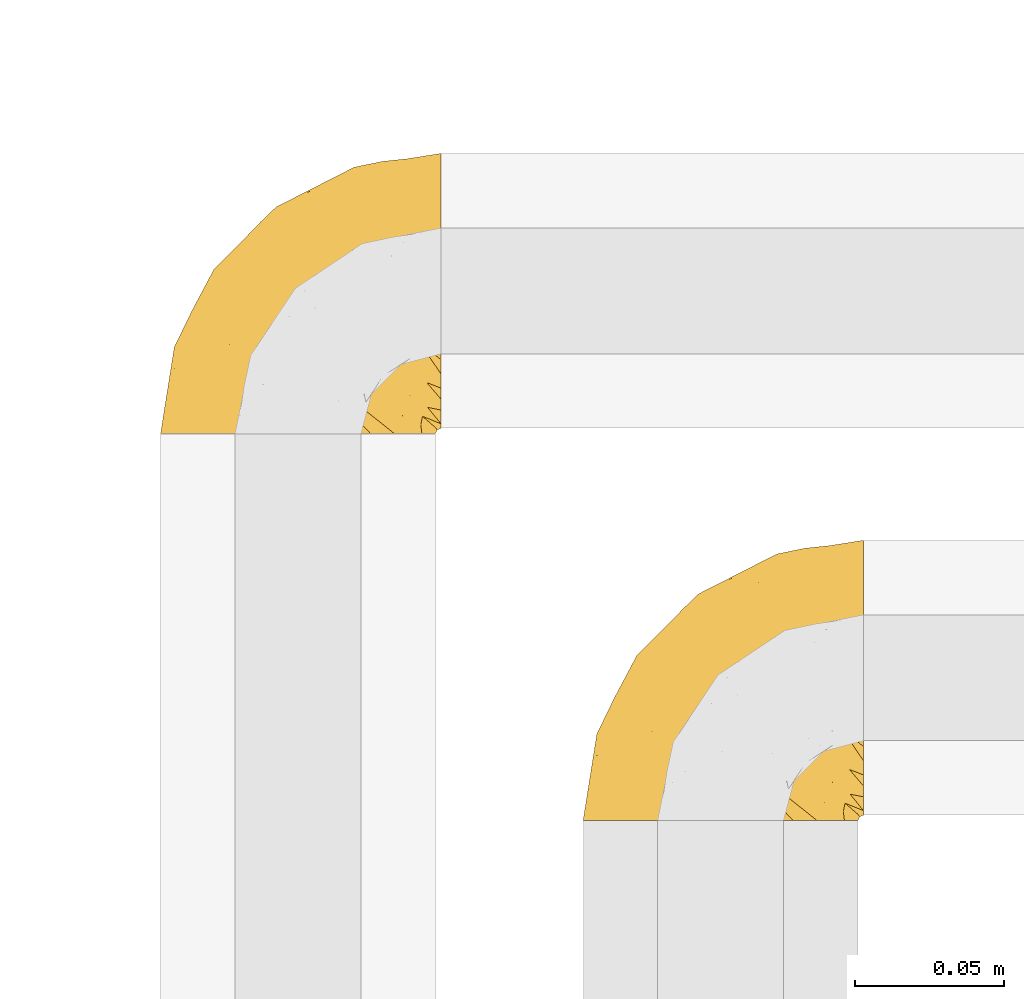
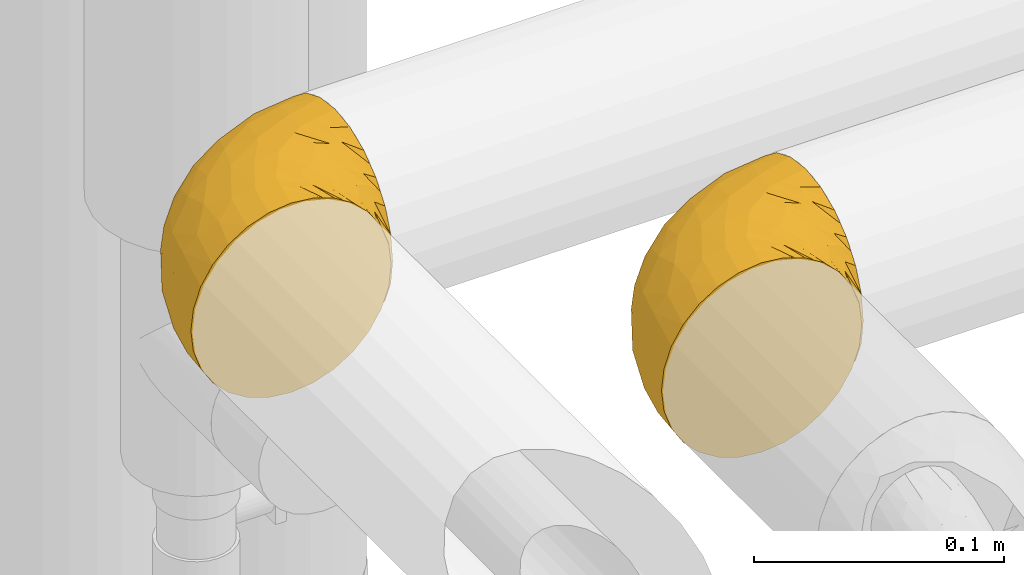
# One storey, part 248 of 827: 2 coverings.
"""IFC2X3 building model written with IfcOpenShell, lengths in millimetres."""

from ifc_helpers import new_model, entity, si_unit, converted_unit, derived_unit, direction, frame, origin, place, context, subcontext, project, spatial, faceted_brep, element, save


model = new_model("IFC2X3")

# Units and contexts
model_context = context("Model", 3, precision=0.01, world=origin(), true_north=direction((6.12303176911189e-17, 1.0)))
body_context = subcontext(model_context, "Body", "Model", "MODEL_VIEW")
ifc_project = project(units=[si_unit("LENGTHUNIT", "METRE", prefix="MILLI"), si_unit("AREAUNIT", "SQUARE_METRE"), si_unit("VOLUMEUNIT", "CUBIC_METRE"), converted_unit("PLANEANGLEUNIT", "DEGREE", entity("IfcRatioMeasure", 0.0174532925199433), si_unit("PLANEANGLEUNIT", "RADIAN"), dimensions=[0, 0, 0, 0, 0, 0, 0]), si_unit("MASSUNIT", "GRAM", prefix="KILO"), derived_unit("MASSDENSITYUNIT", [(si_unit("MASSUNIT", "GRAM", prefix="KILO"), 1), (si_unit("LENGTHUNIT", "METRE"), -3)]), derived_unit("MOMENTOFINERTIAUNIT", [(si_unit("LENGTHUNIT", "METRE"), 4)]), si_unit("TIMEUNIT", "SECOND"), si_unit("FREQUENCYUNIT", "HERTZ"), si_unit("THERMODYNAMICTEMPERATUREUNIT", "DEGREE_CELSIUS"), derived_unit("THERMALTRANSMITTANCEUNIT", [(si_unit("MASSUNIT", "GRAM", prefix="KILO"), 1), (si_unit("THERMODYNAMICTEMPERATUREUNIT", "KELVIN"), -1), (si_unit("TIMEUNIT", "SECOND"), -3)]), derived_unit("VOLUMETRICFLOWRATEUNIT", [(si_unit("LENGTHUNIT", "METRE"), 3), (si_unit("TIMEUNIT", "SECOND"), -1)]), derived_unit("MASSFLOWRATEUNIT", [(si_unit("MASSUNIT", "GRAM", prefix="KILO"), 1), (si_unit("TIMEUNIT", "SECOND"), -1)]), derived_unit("ROTATIONALFREQUENCYUNIT", [(si_unit("TIMEUNIT", "SECOND"), -1)]), si_unit("ELECTRICCURRENTUNIT", "AMPERE"), si_unit("ELECTRICVOLTAGEUNIT", "VOLT"), si_unit("POWERUNIT", "WATT"), si_unit("FORCEUNIT", "NEWTON", prefix="KILO"), si_unit("ILLUMINANCEUNIT", "LUX"), si_unit("LUMINOUSFLUXUNIT", "LUMEN"), si_unit("LUMINOUSINTENSITYUNIT", "CANDELA"), derived_unit("USERDEFINED", [(si_unit("MASSUNIT", "GRAM", prefix="KILO"), -1), (si_unit("LENGTHUNIT", "METRE"), -2), (si_unit("TIMEUNIT", "SECOND"), 3), (si_unit("LUMINOUSFLUXUNIT", "LUMEN"), 1)]), derived_unit("LINEARVELOCITYUNIT", [(si_unit("LENGTHUNIT", "METRE"), 1), (si_unit("TIMEUNIT", "SECOND"), -1)]), si_unit("PRESSUREUNIT", "PASCAL"), derived_unit("USERDEFINED", [(si_unit("LENGTHUNIT", "METRE"), -2), (si_unit("MASSUNIT", "GRAM", prefix="KILO"), 1), (si_unit("TIMEUNIT", "SECOND"), -2)]), derived_unit("LINEARFORCEUNIT", [(si_unit("MASSUNIT", "GRAM", prefix="KILO"), 1), (si_unit("LENGTHUNIT", "METRE"), 1), (si_unit("TIMEUNIT", "SECOND"), -2), (si_unit("LENGTHUNIT", "METRE"), -1)]), derived_unit("PLANARFORCEUNIT", [(si_unit("MASSUNIT", "GRAM", prefix="KILO"), 1), (si_unit("LENGTHUNIT", "METRE"), 1), (si_unit("TIMEUNIT", "SECOND"), -2), (si_unit("LENGTHUNIT", "METRE"), -2)])], contexts=[model_context])

# Site, building, storey
site_placement = place(None, origin())
site = spatial("IfcSite", under=ifc_project, at=site_placement, CompositionType="ELEMENT")
building_placement = place(site_placement, origin())
building = spatial("IfcBuilding", under=site, at=building_placement, CompositionType="ELEMENT")
storey_placement = place(building_placement, frame((0.0, 0.0, 28200.0)))
storey = spatial("IfcBuildingStorey", under=building, at=storey_placement, Name="08", CompositionType="ELEMENT", Elevation=28200.0)

# Coverings
covering_1_placement = place(storey_placement, frame((30515.73, 16011.61, 3152.2)))
element("IfcCovering", 1, at=covering_1_placement, inside=storey, Name=":ADSK_", ObjectType=":ADSK_", PredefinedType="INSULATION", context=body_context, shape_type="Brep", body=[
    faceted_brep([(37.51, 1.6, 92.84), (27.74, 1.6, 89.42), (18.98, 1.6, 83.91), (11.67, 1.6, 76.59), (6.17, 1.6, 67.83), (2.75, 1.6, 58.07), (1.6, 1.6, 47.8), (2.75, 1.6, 37.51), (6.17, 1.6, 27.74), (11.68, 1.6, 18.98), (19.0, 1.6, 11.67), (27.76, 1.6, 6.17), (37.52, 1.6, 2.75), (47.8, 1.6, 1.6), (51.94, 1.6, 2.06), (55.01, 1.6, 2.41), (58.08, 1.6, 2.75), (62.96, 1.6, 4.46), (67.85, 1.6, 6.17), (72.23, 1.6, 8.93), (76.61, 1.6, 11.68), (80.26, 1.6, 15.34), (83.92, 1.6, 19.0), (89.42, 1.6, 27.76), (91.13, 1.6, 32.64), (92.84, 1.6, 37.52), (94.0, 1.6, 47.8), (92.84, 1.6, 58.08), (91.13, 1.6, 62.96), (89.42, 1.6, 67.85), (83.91, 1.6, 76.61), (80.25, 1.6, 80.26), (76.59, 1.6, 83.92), (72.21, 1.6, 86.67), (67.83, 1.6, 89.42), (62.95, 1.6, 91.13), (58.07, 1.6, 92.84), (55.0, 1.6, 93.18), (51.94, 1.6, 93.53), (47.8, 1.6, 94.0), (95.8, 3.4, 47.8), (95.8, 4.97, 35.84), (95.8, 9.58, 24.7), (95.8, 13.26, 19.91), (95.8, 16.93, 15.13), (95.8, 21.71, 11.46), (95.8, 26.5, 7.78), (95.8, 32.07, 5.48), (95.8, 37.64, 3.17), (95.8, 41.25, 2.69), (95.8, 43.34, 2.42), (95.8, 45.42, 2.14), (95.8, 49.6, 1.6), (95.8, 61.55, 3.17), (95.8, 72.7, 7.78), (95.8, 82.26, 15.13), (95.8, 89.61, 24.7), (95.8, 94.22, 35.84), (95.8, 95.8, 47.8), (95.8, 94.22, 59.75), (95.8, 89.61, 70.9), (95.8, 82.26, 80.46), (95.8, 72.7, 87.81), (95.8, 61.55, 92.42), (95.8, 49.6, 94.0), (95.8, 45.42, 93.45), (95.8, 41.25, 92.9), (95.8, 37.64, 92.42), (95.8, 32.07, 90.11), (95.8, 26.5, 87.81), (95.8, 21.71, 84.13), (95.8, 16.93, 80.46), (95.8, 13.26, 75.68), (95.8, 9.58, 70.9), (95.8, 4.97, 59.75), (60.58, 81.55, 71.98), (74.11, 90.4, 63.6), (51.59, 83.0, 59.72), (66.69, 91.18, 47.8), (76.19, 93.13, 55.16), (84.43, 94.0, 47.8), (31.2, 66.19, 63.76), (42.88, 70.92, 72.22), (79.41, 85.95, 74.18), (60.7, 49.74, 92.52), (61.85, 35.54, 94.0), (65.75, 38.14, 94.0), (69.64, 40.74, 94.0), (73.53, 43.34, 94.0), (77.43, 45.94, 94.0), (74.59, 77.59, 82.14), (54.72, 71.17, 80.34), (64.18, 65.81, 87.52), (37.94, 59.03, 79.59), (25.89, 45.85, 78.25), (34.73, 45.79, 85.01), (42.89, 41.42, 90.25), (49.83, 34.51, 93.2), (48.58, 56.04, 87.23), (22.41, 15.15, 85.55), (78.69, 56.51, 93.0), (81.64, 68.39, 89.31), (6.22, 23.33, 61.31), (12.11, 42.86, 56.86), (14.81, 39.42, 68.34), (21.61, 53.58, 65.71), (22.41, 59.17, 56.99), (30.12, 59.06, 72.15), (10.01, 22.63, 70.34), (15.36, 20.55, 78.36), (3.39, 12.96, 47.8), (19.59, 56.96, 47.8), (30.01, 67.38, 47.8), (41.19, 18.72, 93.06), (48.54, 5.33, 94.0), (49.28, 9.07, 94.0), (49.82, 11.79, 94.0), (50.37, 14.51, 94.0), (50.91, 17.24, 94.0), (51.45, 19.96, 94.0), (31.61, 21.03, 89.88), (80.15, 46.48, 94.0), (82.88, 47.03, 94.0), (85.6, 47.57, 94.0), (88.32, 48.11, 94.0), (90.19, 48.48, 94.0), (92.06, 48.85, 94.0), (6.21, 30.7, 47.8), (54.05, 23.86, 94.0), (56.65, 27.75, 94.0), (59.25, 31.64, 94.0), (24.66, 31.26, 83.7), (40.43, 77.8, 47.8), (35.17, 72.75, 55.9), (12.9, 43.83, 47.8), (53.56, 84.49, 47.8), (85.34, 14.58, 81.75), (78.44, 16.17, 86.43), (84.37, 10.82, 79.8), (89.05, 4.64, 69.84), (82.76, 7.71, 79.5), (86.31, 25.13, 88.08), (83.73, 32.66, 91.6), (77.31, 34.94, 92.93), (87.78, 36.76, 92.43), (87.91, 40.48, 93.24), (81.29, 39.25, 93.36), (93.97, 3.69, 57.25), (70.76, 13.99, 89.41), (63.67, 21.85, 92.89), (62.62, 17.93, 92.66), (90.64, 15.11, 79.58), (84.08, 21.14, 86.51), (76.28, 12.7, 86.29), (77.45, 7.21, 83.91), (91.35, 10.45, 73.94), (88.72, 32.27, 90.94), (71.28, 25.68, 91.94), (68.09, 22.18, 91.98), (91.07, 18.79, 82.79), (57.47, 10.12, 93.16), (70.34, 9.47, 88.76), (62.99, 11.29, 91.89), (94.52, 2.87, 47.8), (76.47, 31.16, 92.22), (69.96, 6.31, 88.56), (89.86, 25.62, 87.72), (78.94, 21.18, 88.33), (73.51, 28.81, 92.18), (89.62, 7.45, 71.78), (84.09, 21.14, 9.09), (86.3, 25.13, 7.51), (91.06, 18.79, 12.8), (88.32, 48.11, 1.6), (92.06, 48.85, 1.6), (82.88, 47.03, 1.6), (85.6, 47.57, 1.6), (93.97, 3.69, 38.35), (89.63, 7.44, 23.84), (50.37, 14.51, 1.6), (49.82, 11.79, 1.6), (48.54, 5.33, 1.6), (49.28, 9.07, 1.6), (82.77, 7.71, 16.1), (70.36, 9.47, 6.84), (77.31, 34.94, 2.66), (76.47, 31.16, 3.37), (69.64, 40.74, 1.6), (65.75, 38.14, 1.6), (87.78, 36.76, 3.16), (87.91, 40.48, 2.35), (89.06, 4.63, 25.77), (90.65, 15.11, 16.02), (85.35, 14.58, 13.85), (73.53, 43.34, 1.6), (77.43, 45.94, 1.6), (81.29, 39.25, 2.23), (77.46, 7.21, 11.69), (76.29, 12.69, 9.31), (57.47, 10.14, 2.43), (63.71, 21.81, 2.71), (68.11, 22.19, 3.61), (70.77, 14.0, 6.18), (71.31, 25.69, 3.66), (78.46, 16.17, 9.17), (69.52, 6.66, 6.77), (62.64, 17.92, 2.93), (91.35, 10.45, 21.66), (59.25, 31.64, 1.6), (84.6, 10.64, 16.09), (62.98, 11.31, 3.7), (51.45, 19.96, 1.6), (54.05, 23.86, 1.6), (56.65, 27.75, 1.6), (83.73, 32.66, 3.99), (80.15, 46.48, 1.6), (88.72, 32.27, 4.65), (61.85, 35.54, 1.6), (73.56, 28.77, 3.43), (78.96, 21.17, 7.27), (91.36, 23.36, 9.46), (50.91, 17.24, 1.6), (62.87, 47.58, 2.4), (76.19, 93.13, 40.43), (73.57, 77.44, 13.57), (56.07, 66.78, 11.3), (49.77, 71.68, 18.65), (44.73, 74.96, 27.26), (60.58, 81.55, 23.61), (47.64, 36.7, 3.07), (78.32, 56.9, 2.69), (51.59, 83.0, 35.87), (74.11, 90.4, 31.99), (76.04, 67.83, 6.71), (79.41, 85.95, 21.41), (14.82, 39.41, 27.24), (6.22, 23.33, 34.26), (12.12, 42.87, 38.73), (23.51, 53.92, 26.97), (31.2, 66.19, 31.83), (34.96, 64.12, 23.4), (33.86, 33.13, 6.91), (38.94, 23.1, 3.4), (30.23, 16.98, 5.84), (35.17, 72.75, 39.69), (15.85, 23.77, 17.6), (22.59, 18.41, 10.38), (21.56, 43.7, 20.6), (55.94, 54.53, 5.36), (20.67, 55.72, 35.73), (9.19, 17.73, 24.84), (25.79, 38.98, 13.87), (41.16, 50.28, 9.06), (37.95, 59.02, 15.99)], [[[0, 1, 2, 3, 4, 5, 6, 7, 8, 9, 10, 11, 12, 13, 14, 15, 16, 17, 18, 19, 20, 21, 22, 23, 24, 25, 26, 27, 28, 29, 30, 31, 32, 33, 34, 35, 36, 37, 38, 39]], [[40, 41, 42, 43, 44, 45, 46, 47, 48, 49, 50, 51, 52, 53, 54, 55, 56, 57, 58, 59, 60, 61, 62, 63, 64, 65, 66, 67, 68, 69, 70, 71, 72, 73, 74]], [[75, 76, 77]], [[78, 79, 80]], [[77, 81, 82]], [[76, 75, 83]], [[84, 85, 86, 87, 88, 89]], [[90, 91, 92]], [[76, 60, 59]], [[93, 94, 95]], [[90, 62, 61]], [[83, 61, 60]], [[96, 97, 84]], [[98, 93, 95]], [[2, 1, 99]], [[100, 84, 89]], [[62, 101, 63]], [[4, 102, 5]], [[92, 84, 100]], [[103, 102, 104]], [[103, 105, 106]], [[93, 107, 94]], [[3, 108, 4]], [[92, 101, 90]], [[108, 3, 109]], [[102, 110, 5]], [[93, 82, 107]], [[102, 108, 104]], [[111, 106, 112]], [[109, 2, 99]], [[113, 39, 114, 115, 116, 117, 118, 119]], [[120, 0, 113]], [[100, 89, 121, 122, 123, 124, 125, 126, 64]], [[127, 102, 103]], [[97, 119, 128, 129, 130, 85]], [[99, 120, 131]], [[132, 133, 77]], [[59, 80, 79]], [[3, 2, 109]], [[98, 84, 92]], [[94, 109, 131]], [[120, 1, 0]], [[93, 91, 82]], [[104, 94, 105]], [[97, 113, 119]], [[95, 120, 96]], [[83, 90, 61]], [[91, 93, 98]], [[64, 63, 100]], [[100, 63, 101]], [[77, 76, 79]], [[133, 106, 81]], [[84, 97, 85]], [[113, 96, 120]], [[113, 97, 96]], [[39, 113, 0]], [[110, 102, 127]], [[110, 6, 5]], [[103, 111, 134, 127]], [[90, 75, 91]], [[82, 81, 107]], [[91, 75, 82]], [[77, 82, 75]], [[76, 83, 60]], [[90, 83, 75]], [[105, 107, 81]], [[94, 131, 95]], [[105, 94, 107]], [[109, 94, 104]], [[120, 95, 131]], [[98, 95, 96]], [[84, 98, 96]], [[98, 92, 91]], [[106, 105, 81]], [[103, 104, 105]], [[112, 106, 133]], [[103, 106, 111]], [[112, 133, 132]], [[81, 77, 133]], [[77, 78, 135, 132]], [[120, 99, 1]], [[109, 99, 131]], [[59, 58, 80]], [[59, 79, 76]], [[90, 101, 62]], [[100, 101, 92]], [[4, 108, 102]], [[109, 104, 108]], [[78, 77, 79]], [[136, 137, 138]], [[29, 139, 140]], [[141, 142, 143]], [[144, 145, 121]], [[146, 89, 88]], [[147, 139, 27]], [[148, 149, 150]], [[136, 151, 152]], [[147, 40, 74]], [[26, 147, 27]], [[140, 153, 154]], [[35, 116, 36]], [[73, 151, 155]], [[114, 39, 38, 37, 36, 116, 115]], [[146, 156, 144]], [[157, 85, 130]], [[158, 149, 148]], [[151, 159, 152]], [[117, 35, 160]], [[31, 154, 161]], [[155, 74, 73]], [[162, 128, 119]], [[66, 65, 64, 126, 125, 124, 123, 122, 67]], [[163, 147, 26]], [[29, 140, 30]], [[149, 129, 150]], [[139, 29, 28, 27]], [[68, 144, 69]], [[129, 128, 150]], [[164, 87, 86]], [[130, 129, 149]], [[122, 145, 67]], [[154, 153, 148]], [[162, 119, 160]], [[165, 32, 161]], [[150, 161, 148]], [[128, 162, 150]], [[32, 165, 33]], [[145, 144, 68]], [[89, 146, 144]], [[87, 164, 143]], [[166, 156, 142]], [[88, 87, 143]], [[162, 161, 150]], [[161, 32, 31]], [[154, 31, 30]], [[140, 154, 30]], [[161, 154, 148]], [[140, 137, 153]], [[158, 148, 153]], [[157, 130, 158]], [[153, 137, 158]], [[158, 137, 157]], [[167, 137, 136]], [[168, 85, 157]], [[152, 168, 167]], [[167, 168, 157]], [[164, 152, 141]], [[151, 73, 72]], [[159, 72, 71]], [[88, 142, 146]], [[144, 156, 69]], [[146, 142, 156]], [[70, 166, 71]], [[142, 141, 166]], [[70, 69, 156]], [[141, 159, 71]], [[167, 136, 152]], [[138, 137, 140]], [[155, 136, 169]], [[136, 155, 151]], [[74, 155, 169]], [[152, 159, 141]], [[151, 72, 159]], [[168, 152, 164]], [[137, 167, 157]], [[164, 86, 168]], [[85, 168, 86]], [[116, 35, 117]], [[130, 149, 158]], [[67, 145, 68]], [[121, 89, 144]], [[145, 122, 121]], [[40, 147, 163]], [[169, 147, 74]], [[160, 35, 34]], [[162, 160, 34]], [[160, 119, 118, 117]], [[139, 147, 169]], [[139, 169, 138]], [[162, 34, 33]], [[141, 143, 164]], [[88, 143, 142]], [[71, 166, 141]], [[156, 166, 70]], [[139, 138, 140]], [[169, 136, 138]], [[161, 162, 165]], [[162, 33, 165]], [[170, 171, 172]], [[173, 174, 52, 51, 50, 49, 48, 175, 176]], [[177, 178, 41]], [[179, 17, 180]], [[14, 13, 181, 182, 180, 16, 15]], [[183, 23, 22]], [[21, 20, 184]], [[185, 186, 187]], [[186, 188, 187]], [[43, 172, 44]], [[189, 190, 47]], [[25, 24, 23, 191]], [[170, 192, 193]], [[40, 163, 177]], [[194, 195, 196]], [[26, 25, 177]], [[197, 198, 183]], [[199, 17, 179]], [[178, 177, 191]], [[47, 46, 189]], [[200, 201, 202]], [[201, 203, 204]], [[205, 206, 184]], [[207, 41, 178]], [[18, 17, 199]], [[16, 180, 17]], [[202, 201, 198]], [[208, 201, 200]], [[163, 26, 177]], [[48, 47, 190]], [[196, 195, 189]], [[197, 184, 202]], [[204, 193, 209]], [[210, 211, 212]], [[206, 212, 213]], [[205, 19, 210]], [[184, 206, 202]], [[210, 212, 206]], [[185, 194, 214]], [[189, 215, 190]], [[216, 45, 214]], [[186, 171, 170]], [[189, 216, 196]], [[197, 22, 21]], [[194, 185, 187]], [[197, 183, 22]], [[184, 197, 21]], [[197, 202, 198]], [[206, 200, 202]], [[204, 183, 198]], [[201, 208, 203]], [[203, 208, 217]], [[204, 198, 201]], [[217, 188, 218]], [[193, 219, 170]], [[171, 186, 185]], [[170, 218, 186]], [[170, 219, 218]], [[42, 207, 192]], [[171, 220, 172]], [[216, 189, 46]], [[214, 194, 196]], [[44, 220, 45]], [[214, 196, 216]], [[216, 46, 45]], [[214, 45, 220]], [[192, 43, 42]], [[204, 203, 219]], [[207, 193, 192]], [[209, 193, 178]], [[41, 207, 42]], [[193, 207, 178]], [[43, 192, 172]], [[170, 172, 192]], [[204, 219, 193]], [[219, 203, 218]], [[217, 218, 203]], [[188, 186, 218]], [[206, 213, 200]], [[208, 200, 213]], [[199, 210, 18]], [[215, 189, 195]], [[215, 175, 190]], [[175, 48, 190]], [[199, 179, 221, 211]], [[210, 199, 211]], [[25, 191, 177]], [[40, 177, 41]], [[191, 183, 209]], [[23, 183, 191]], [[205, 20, 19]], [[19, 18, 210]], [[171, 185, 214]], [[172, 220, 44]], [[214, 220, 171]], [[191, 209, 178]], [[204, 209, 183]], [[206, 205, 210]], [[20, 205, 184]], [[222, 195, 194, 187, 188, 217]], [[57, 223, 80]], [[224, 225, 226]], [[226, 227, 228]], [[229, 217, 208, 213, 212, 211]], [[230, 52, 174, 173, 176, 175, 215, 195]], [[231, 232, 228]], [[231, 78, 223]], [[223, 57, 232]], [[224, 233, 225]], [[233, 54, 53]], [[234, 232, 56]], [[56, 55, 234]], [[234, 224, 228]], [[235, 236, 237]], [[224, 55, 54]], [[238, 239, 240]], [[52, 230, 53]], [[241, 242, 243]], [[231, 227, 244]], [[13, 12, 242]], [[236, 8, 7]], [[9, 245, 10]], [[10, 246, 11]], [[238, 247, 235]], [[222, 229, 248]], [[242, 211, 221, 179, 180, 182, 181, 13]], [[233, 53, 230]], [[111, 112, 249]], [[250, 8, 236]], [[246, 251, 241]], [[8, 250, 9]], [[127, 236, 110]], [[248, 229, 252]], [[246, 10, 245]], [[235, 245, 250]], [[236, 7, 110]], [[235, 249, 238]], [[237, 236, 127]], [[243, 11, 246]], [[252, 229, 241]], [[56, 232, 57]], [[222, 230, 195]], [[225, 248, 252]], [[248, 233, 230]], [[54, 233, 224]], [[231, 228, 227]], [[244, 132, 231]], [[248, 225, 233]], [[226, 225, 253]], [[235, 250, 236]], [[245, 9, 250]], [[251, 246, 245]], [[243, 246, 241]], [[247, 245, 235]], [[252, 251, 253]], [[229, 222, 217]], [[230, 222, 248]], [[7, 6, 110]], [[237, 127, 134, 111]], [[238, 249, 239]], [[224, 234, 55]], [[232, 234, 228]], [[242, 241, 229]], [[12, 11, 243]], [[211, 242, 229]], [[12, 243, 242]], [[80, 223, 78]], [[80, 58, 57]], [[231, 223, 232]], [[227, 240, 239]], [[224, 226, 228]], [[240, 226, 253]], [[227, 239, 244]], [[226, 240, 227]], [[251, 247, 253]], [[240, 253, 247]], [[249, 235, 237]], [[237, 111, 249]], [[244, 239, 249]], [[112, 244, 249]], [[135, 78, 231, 132]], [[112, 132, 244]], [[247, 238, 240]], [[245, 247, 251]], [[251, 252, 241]], [[225, 252, 253]]]),
])
covering_2_placement = place(storey_placement, frame((30373.73, 16141.61, 3152.2)))
element("IfcCovering", 2, at=covering_2_placement, inside=storey, Name=":ADSK_", ObjectType=":ADSK_", PredefinedType="INSULATION", context=body_context, shape_type="Brep", body=[
    faceted_brep([(18.98, 1.6, 83.91), (11.67, 1.6, 76.59), (6.17, 1.6, 67.83), (2.75, 1.6, 58.07), (1.6, 1.6, 47.8), (2.75, 1.6, 37.51), (6.17, 1.6, 27.74), (11.68, 1.6, 18.98), (19.0, 1.6, 11.67), (27.76, 1.6, 6.17), (37.52, 1.6, 2.75), (47.8, 1.6, 1.6), (51.94, 1.6, 2.06), (55.01, 1.6, 2.41), (58.08, 1.6, 2.75), (62.96, 1.6, 4.46), (67.85, 1.6, 6.17), (72.23, 1.6, 8.93), (76.61, 1.6, 11.68), (80.26, 1.6, 15.34), (83.92, 1.6, 19.0), (89.42, 1.6, 27.76), (91.13, 1.6, 32.64), (92.84, 1.6, 37.52), (94.0, 1.6, 47.8), (92.84, 1.6, 58.08), (91.13, 1.6, 62.96), (89.42, 1.6, 67.85), (83.91, 1.6, 76.61), (80.25, 1.6, 80.26), (76.59, 1.6, 83.92), (72.21, 1.6, 86.67), (67.83, 1.6, 89.42), (62.95, 1.6, 91.13), (58.07, 1.6, 92.84), (55.0, 1.6, 93.18), (51.94, 1.6, 93.53), (47.8, 1.6, 94.0), (37.51, 1.6, 92.84), (27.74, 1.6, 89.42), (95.8, 3.4, 47.8), (95.8, 4.97, 35.84), (95.8, 9.58, 24.7), (95.8, 13.26, 19.91), (95.8, 16.93, 15.13), (95.8, 21.71, 11.46), (95.8, 26.5, 7.78), (95.8, 32.07, 5.48), (95.8, 37.64, 3.17), (95.8, 41.25, 2.69), (95.8, 43.34, 2.42), (95.8, 45.42, 2.14), (95.8, 49.6, 1.6), (95.8, 61.55, 3.17), (95.8, 72.7, 7.78), (95.8, 82.26, 15.13), (95.8, 89.61, 24.7), (95.8, 94.22, 35.84), (95.8, 95.8, 47.8), (95.8, 94.22, 59.75), (95.8, 89.61, 70.9), (95.8, 82.26, 80.46), (95.8, 72.7, 87.81), (95.8, 61.55, 92.42), (95.8, 49.6, 94.0), (95.8, 45.42, 93.45), (95.8, 41.25, 92.9), (95.8, 37.64, 92.42), (95.8, 32.07, 90.11), (95.8, 26.5, 87.81), (95.8, 21.71, 84.13), (95.8, 16.93, 80.46), (95.8, 13.26, 75.68), (95.8, 9.58, 70.9), (95.8, 4.97, 59.75), (60.58, 81.55, 71.98), (74.11, 90.4, 63.6), (51.59, 83.0, 59.72), (66.69, 91.18, 47.8), (76.19, 93.13, 55.16), (84.43, 94.0, 47.8), (31.2, 66.19, 63.76), (42.88, 70.92, 72.22), (79.41, 85.95, 74.18), (60.7, 49.74, 92.52), (61.85, 35.54, 94.0), (65.75, 38.14, 94.0), (69.64, 40.74, 94.0), (73.53, 43.34, 94.0), (77.43, 45.94, 94.0), (74.59, 77.59, 82.14), (54.72, 71.17, 80.34), (64.18, 65.81, 87.52), (37.94, 59.03, 79.59), (25.89, 45.85, 78.25), (34.73, 45.79, 85.01), (42.89, 41.42, 90.25), (49.83, 34.51, 93.2), (48.58, 56.04, 87.23), (22.41, 15.15, 85.55), (78.69, 56.51, 93.0), (81.64, 68.39, 89.31), (6.22, 23.33, 61.31), (12.11, 42.86, 56.86), (14.81, 39.42, 68.34), (21.61, 53.58, 65.71), (22.41, 59.17, 56.99), (30.12, 59.06, 72.15), (10.01, 22.63, 70.34), (15.36, 20.55, 78.36), (3.39, 12.96, 47.8), (19.59, 56.96, 47.8), (30.01, 67.38, 47.8), (41.19, 18.72, 93.06), (48.54, 5.33, 94.0), (49.28, 9.07, 94.0), (49.82, 11.79, 94.0), (50.37, 14.51, 94.0), (50.91, 17.24, 94.0), (51.45, 19.96, 94.0), (31.61, 21.03, 89.88), (80.15, 46.48, 94.0), (82.88, 47.03, 94.0), (85.6, 47.57, 94.0), (88.32, 48.11, 94.0), (90.19, 48.48, 94.0), (92.06, 48.85, 94.0), (6.21, 30.7, 47.8), (54.05, 23.86, 94.0), (56.65, 27.75, 94.0), (59.25, 31.64, 94.0), (24.66, 31.26, 83.7), (40.43, 77.8, 47.8), (35.17, 72.75, 55.9), (12.9, 43.83, 47.8), (53.56, 84.49, 47.8), (85.34, 14.58, 81.75), (78.44, 16.17, 86.43), (84.37, 10.82, 79.8), (89.05, 4.64, 69.84), (82.76, 7.71, 79.5), (86.31, 25.13, 88.08), (83.73, 32.66, 91.6), (77.31, 34.94, 92.93), (87.78, 36.76, 92.43), (87.91, 40.48, 93.24), (81.29, 39.25, 93.36), (93.97, 3.69, 57.25), (70.76, 13.99, 89.41), (63.67, 21.85, 92.89), (62.62, 17.93, 92.66), (90.64, 15.11, 79.58), (84.08, 21.14, 86.51), (76.28, 12.7, 86.29), (77.45, 7.21, 83.91), (91.35, 10.45, 73.94), (88.72, 32.27, 90.94), (71.28, 25.68, 91.94), (68.09, 22.18, 91.98), (91.07, 18.79, 82.79), (57.47, 10.12, 93.16), (70.34, 9.47, 88.76), (62.99, 11.29, 91.89), (94.52, 2.87, 47.8), (76.47, 31.16, 92.22), (69.96, 6.31, 88.56), (89.86, 25.62, 87.72), (78.94, 21.18, 88.33), (73.51, 28.81, 92.18), (89.62, 7.45, 71.78), (84.09, 21.14, 9.09), (86.3, 25.13, 7.51), (91.06, 18.79, 12.8), (88.32, 48.11, 1.6), (92.06, 48.85, 1.6), (82.88, 47.03, 1.6), (85.6, 47.57, 1.6), (93.97, 3.69, 38.35), (89.63, 7.44, 23.84), (50.37, 14.51, 1.6), (49.82, 11.79, 1.6), (48.54, 5.33, 1.6), (49.28, 9.07, 1.6), (82.77, 7.71, 16.1), (70.36, 9.47, 6.84), (77.31, 34.94, 2.66), (76.47, 31.16, 3.37), (69.64, 40.74, 1.6), (65.75, 38.14, 1.6), (87.78, 36.76, 3.16), (87.91, 40.48, 2.35), (89.06, 4.63, 25.77), (90.65, 15.11, 16.02), (85.35, 14.58, 13.85), (73.53, 43.34, 1.6), (77.43, 45.94, 1.6), (81.29, 39.25, 2.23), (77.46, 7.21, 11.69), (76.29, 12.69, 9.31), (57.47, 10.14, 2.43), (63.71, 21.81, 2.71), (68.11, 22.19, 3.61), (70.77, 14.0, 6.18), (71.31, 25.69, 3.66), (78.46, 16.17, 9.17), (69.52, 6.66, 6.77), (62.64, 17.92, 2.93), (91.35, 10.45, 21.66), (59.25, 31.64, 1.6), (84.6, 10.64, 16.09), (62.98, 11.31, 3.7), (51.45, 19.96, 1.6), (54.05, 23.86, 1.6), (56.65, 27.75, 1.6), (83.73, 32.66, 3.99), (80.15, 46.48, 1.6), (88.72, 32.27, 4.65), (61.85, 35.54, 1.6), (73.56, 28.77, 3.43), (78.96, 21.17, 7.27), (91.36, 23.36, 9.46), (50.91, 17.24, 1.6), (62.87, 47.58, 2.4), (76.19, 93.13, 40.43), (73.57, 77.44, 13.57), (56.07, 66.78, 11.3), (49.77, 71.68, 18.65), (44.73, 74.96, 27.26), (60.58, 81.55, 23.61), (47.64, 36.7, 3.07), (78.32, 56.9, 2.69), (51.59, 83.0, 35.87), (74.11, 90.4, 31.99), (76.04, 67.83, 6.71), (79.41, 85.95, 21.41), (14.82, 39.41, 27.24), (6.22, 23.33, 34.26), (12.12, 42.87, 38.73), (23.51, 53.92, 26.97), (31.2, 66.19, 31.83), (34.96, 64.12, 23.4), (33.86, 33.13, 6.91), (38.94, 23.1, 3.4), (30.23, 16.98, 5.84), (35.17, 72.75, 39.69), (15.85, 23.77, 17.6), (22.59, 18.41, 10.38), (21.56, 43.7, 20.6), (55.94, 54.53, 5.36), (20.67, 55.72, 35.73), (9.19, 17.73, 24.84), (25.79, 38.98, 13.87), (41.16, 50.28, 9.06), (37.95, 59.02, 15.99)], [[[0, 1, 2, 3, 4, 5, 6, 7, 8, 9, 10, 11, 12, 13, 14, 15, 16, 17, 18, 19, 20, 21, 22, 23, 24, 25, 26, 27, 28, 29, 30, 31, 32, 33, 34, 35, 36, 37, 38, 39]], [[40, 41, 42, 43, 44, 45, 46, 47, 48, 49, 50, 51, 52, 53, 54, 55, 56, 57, 58, 59, 60, 61, 62, 63, 64, 65, 66, 67, 68, 69, 70, 71, 72, 73, 74]], [[75, 76, 77]], [[78, 79, 80]], [[77, 81, 82]], [[76, 75, 83]], [[84, 85, 86, 87, 88, 89]], [[90, 91, 92]], [[76, 60, 59]], [[93, 94, 95]], [[90, 62, 61]], [[83, 61, 60]], [[96, 97, 84]], [[98, 93, 95]], [[0, 39, 99]], [[100, 84, 89]], [[62, 101, 63]], [[2, 102, 3]], [[92, 84, 100]], [[103, 102, 104]], [[103, 105, 106]], [[93, 107, 94]], [[1, 108, 2]], [[92, 101, 90]], [[108, 1, 109]], [[102, 110, 3]], [[93, 82, 107]], [[102, 108, 104]], [[111, 106, 112]], [[109, 0, 99]], [[113, 37, 114, 115, 116, 117, 118, 119]], [[120, 38, 113]], [[100, 89, 121, 122, 123, 124, 125, 126, 64]], [[127, 102, 103]], [[97, 119, 128, 129, 130, 85]], [[99, 120, 131]], [[132, 133, 77]], [[59, 80, 79]], [[1, 0, 109]], [[98, 84, 92]], [[94, 109, 131]], [[120, 39, 38]], [[93, 91, 82]], [[104, 94, 105]], [[97, 113, 119]], [[95, 120, 96]], [[83, 90, 61]], [[91, 93, 98]], [[64, 63, 100]], [[100, 63, 101]], [[77, 76, 79]], [[133, 106, 81]], [[84, 97, 85]], [[113, 96, 120]], [[113, 97, 96]], [[37, 113, 38]], [[110, 102, 127]], [[110, 4, 3]], [[103, 111, 134, 127]], [[90, 75, 91]], [[82, 81, 107]], [[91, 75, 82]], [[77, 82, 75]], [[76, 83, 60]], [[90, 83, 75]], [[105, 107, 81]], [[94, 131, 95]], [[105, 94, 107]], [[109, 94, 104]], [[120, 95, 131]], [[98, 95, 96]], [[84, 98, 96]], [[98, 92, 91]], [[106, 105, 81]], [[103, 104, 105]], [[112, 106, 133]], [[103, 106, 111]], [[112, 133, 132]], [[81, 77, 133]], [[77, 78, 135, 132]], [[120, 99, 39]], [[109, 99, 131]], [[59, 58, 80]], [[59, 79, 76]], [[90, 101, 62]], [[100, 101, 92]], [[2, 108, 102]], [[109, 104, 108]], [[78, 77, 79]], [[136, 137, 138]], [[27, 139, 140]], [[141, 142, 143]], [[144, 145, 121]], [[146, 89, 88]], [[147, 139, 25]], [[148, 149, 150]], [[136, 151, 152]], [[147, 40, 74]], [[24, 147, 25]], [[140, 153, 154]], [[33, 116, 34]], [[73, 151, 155]], [[114, 37, 36, 35, 34, 116, 115]], [[146, 156, 144]], [[157, 85, 130]], [[158, 149, 148]], [[151, 159, 152]], [[117, 33, 160]], [[29, 154, 161]], [[155, 74, 73]], [[162, 128, 119]], [[66, 65, 64, 126, 125, 124, 123, 122, 67]], [[163, 147, 24]], [[27, 140, 28]], [[149, 129, 150]], [[139, 27, 26, 25]], [[68, 144, 69]], [[129, 128, 150]], [[164, 87, 86]], [[130, 129, 149]], [[122, 145, 67]], [[154, 153, 148]], [[162, 119, 160]], [[165, 30, 161]], [[150, 161, 148]], [[128, 162, 150]], [[30, 165, 31]], [[145, 144, 68]], [[89, 146, 144]], [[87, 164, 143]], [[166, 156, 142]], [[88, 87, 143]], [[162, 161, 150]], [[161, 30, 29]], [[154, 29, 28]], [[140, 154, 28]], [[161, 154, 148]], [[140, 137, 153]], [[158, 148, 153]], [[157, 130, 158]], [[153, 137, 158]], [[158, 137, 157]], [[167, 137, 136]], [[168, 85, 157]], [[152, 168, 167]], [[167, 168, 157]], [[164, 152, 141]], [[151, 73, 72]], [[159, 72, 71]], [[88, 142, 146]], [[144, 156, 69]], [[146, 142, 156]], [[70, 166, 71]], [[142, 141, 166]], [[70, 69, 156]], [[141, 159, 71]], [[167, 136, 152]], [[138, 137, 140]], [[155, 136, 169]], [[136, 155, 151]], [[74, 155, 169]], [[152, 159, 141]], [[151, 72, 159]], [[168, 152, 164]], [[137, 167, 157]], [[164, 86, 168]], [[85, 168, 86]], [[116, 33, 117]], [[130, 149, 158]], [[67, 145, 68]], [[121, 89, 144]], [[145, 122, 121]], [[40, 147, 163]], [[169, 147, 74]], [[160, 33, 32]], [[162, 160, 32]], [[160, 119, 118, 117]], [[139, 147, 169]], [[139, 169, 138]], [[162, 32, 31]], [[141, 143, 164]], [[88, 143, 142]], [[71, 166, 141]], [[156, 166, 70]], [[139, 138, 140]], [[169, 136, 138]], [[161, 162, 165]], [[162, 31, 165]], [[170, 171, 172]], [[173, 174, 52, 51, 50, 49, 48, 175, 176]], [[177, 178, 41]], [[179, 15, 180]], [[12, 11, 181, 182, 180, 14, 13]], [[183, 21, 20]], [[19, 18, 184]], [[185, 186, 187]], [[186, 188, 187]], [[43, 172, 44]], [[189, 190, 47]], [[23, 22, 21, 191]], [[170, 192, 193]], [[40, 163, 177]], [[194, 195, 196]], [[24, 23, 177]], [[197, 198, 183]], [[199, 15, 179]], [[178, 177, 191]], [[47, 46, 189]], [[200, 201, 202]], [[201, 203, 204]], [[205, 206, 184]], [[207, 41, 178]], [[16, 15, 199]], [[14, 180, 15]], [[202, 201, 198]], [[208, 201, 200]], [[163, 24, 177]], [[48, 47, 190]], [[196, 195, 189]], [[197, 184, 202]], [[204, 193, 209]], [[210, 211, 212]], [[206, 212, 213]], [[205, 17, 210]], [[184, 206, 202]], [[210, 212, 206]], [[185, 194, 214]], [[189, 215, 190]], [[216, 45, 214]], [[186, 171, 170]], [[189, 216, 196]], [[197, 20, 19]], [[194, 185, 187]], [[197, 183, 20]], [[184, 197, 19]], [[197, 202, 198]], [[206, 200, 202]], [[204, 183, 198]], [[201, 208, 203]], [[203, 208, 217]], [[204, 198, 201]], [[217, 188, 218]], [[193, 219, 170]], [[171, 186, 185]], [[170, 218, 186]], [[170, 219, 218]], [[42, 207, 192]], [[171, 220, 172]], [[216, 189, 46]], [[214, 194, 196]], [[44, 220, 45]], [[214, 196, 216]], [[216, 46, 45]], [[214, 45, 220]], [[192, 43, 42]], [[204, 203, 219]], [[207, 193, 192]], [[209, 193, 178]], [[41, 207, 42]], [[193, 207, 178]], [[43, 192, 172]], [[170, 172, 192]], [[204, 219, 193]], [[219, 203, 218]], [[217, 218, 203]], [[188, 186, 218]], [[206, 213, 200]], [[208, 200, 213]], [[199, 210, 16]], [[215, 189, 195]], [[215, 175, 190]], [[175, 48, 190]], [[199, 179, 221, 211]], [[210, 199, 211]], [[23, 191, 177]], [[40, 177, 41]], [[191, 183, 209]], [[21, 183, 191]], [[205, 18, 17]], [[17, 16, 210]], [[171, 185, 214]], [[172, 220, 44]], [[214, 220, 171]], [[191, 209, 178]], [[204, 209, 183]], [[206, 205, 210]], [[18, 205, 184]], [[222, 195, 194, 187, 188, 217]], [[57, 223, 80]], [[224, 225, 226]], [[226, 227, 228]], [[229, 217, 208, 213, 212, 211]], [[230, 52, 174, 173, 176, 175, 215, 195]], [[231, 232, 228]], [[231, 78, 223]], [[223, 57, 232]], [[224, 233, 225]], [[233, 54, 53]], [[234, 232, 56]], [[56, 55, 234]], [[234, 224, 228]], [[235, 236, 237]], [[224, 55, 54]], [[238, 239, 240]], [[52, 230, 53]], [[241, 242, 243]], [[231, 227, 244]], [[11, 10, 242]], [[236, 6, 5]], [[7, 245, 8]], [[8, 246, 9]], [[238, 247, 235]], [[222, 229, 248]], [[242, 211, 221, 179, 180, 182, 181, 11]], [[233, 53, 230]], [[111, 112, 249]], [[250, 6, 236]], [[246, 251, 241]], [[6, 250, 7]], [[127, 236, 110]], [[248, 229, 252]], [[246, 8, 245]], [[235, 245, 250]], [[236, 5, 110]], [[235, 249, 238]], [[237, 236, 127]], [[243, 9, 246]], [[252, 229, 241]], [[56, 232, 57]], [[222, 230, 195]], [[225, 248, 252]], [[248, 233, 230]], [[54, 233, 224]], [[231, 228, 227]], [[244, 132, 231]], [[248, 225, 233]], [[226, 225, 253]], [[235, 250, 236]], [[245, 7, 250]], [[251, 246, 245]], [[243, 246, 241]], [[247, 245, 235]], [[252, 251, 253]], [[229, 222, 217]], [[230, 222, 248]], [[5, 4, 110]], [[237, 127, 134, 111]], [[238, 249, 239]], [[224, 234, 55]], [[232, 234, 228]], [[242, 241, 229]], [[10, 9, 243]], [[211, 242, 229]], [[10, 243, 242]], [[80, 223, 78]], [[80, 58, 57]], [[231, 223, 232]], [[227, 240, 239]], [[224, 226, 228]], [[240, 226, 253]], [[227, 239, 244]], [[226, 240, 227]], [[251, 247, 253]], [[240, 253, 247]], [[249, 235, 237]], [[237, 111, 249]], [[244, 239, 249]], [[112, 244, 249]], [[135, 78, 231, 132]], [[112, 132, 244]], [[247, 238, 240]], [[245, 247, 251]], [[251, 252, 241]], [[225, 252, 253]]]),
])

save(model, "model.ifc")
